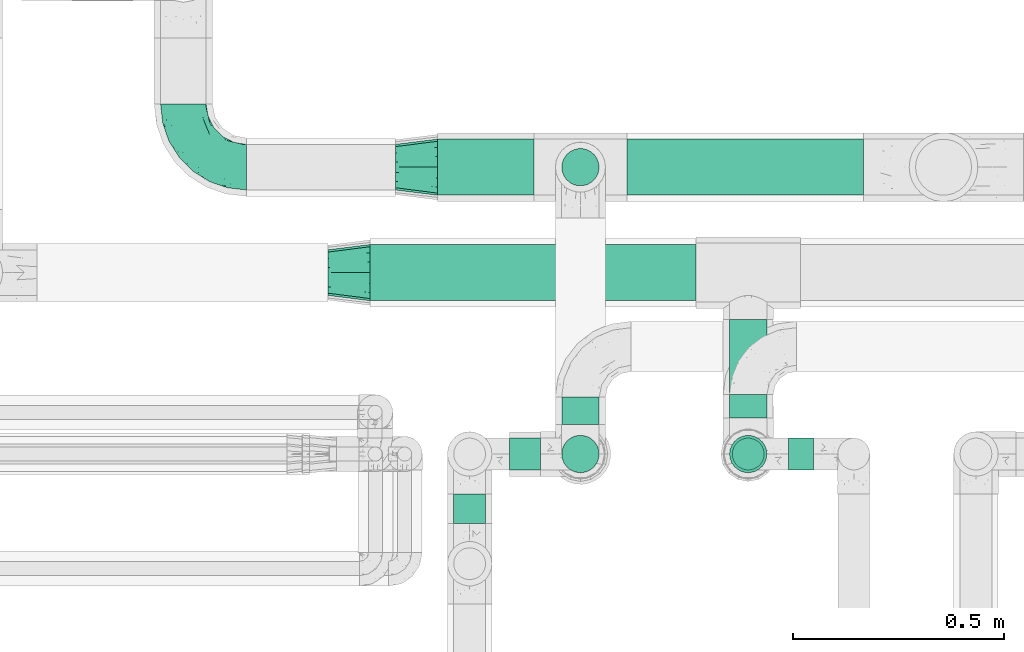
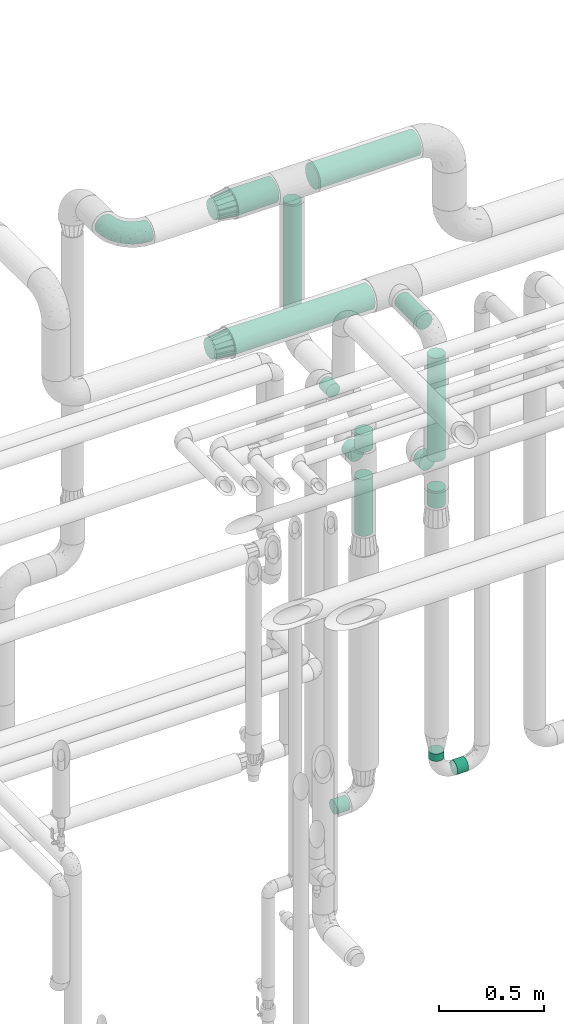
# One storey, part 704 of 827: 15 flow segments, 3 flow fittings.
"""IFC2X3 building model written with IfcOpenShell, lengths in millimetres."""

import ifcopenshell
import ifcopenshell.guid

model = None  # the IFC model being written
_history = None  # IfcOwnerHistory: only IFC2X3 demands one
_inside = {}  # id of a spatial element -> (the spatial element, [elements in it])
_under = {}  # id of a project, library or spatial element -> (it, [spatial elements below it])
_declared = {}  # id of a project -> (the project, [libraries it declares])
_typed = {}  # id of a type object -> (the type object, [elements of that type])
_made_of = {}  # id of a material, layer set ... -> (it, [elements and type objects made of it])


def new_model(schema):
    """Start an empty IFC model of exactly this schema.

    Asked for "IFC4X3", IfcOpenShell would pick the latest addendum, in which some entities
    have other attributes; the version numbers below select the first issue.
    IFC2X3 requires an IfcOwnerHistory on every rooted entity: one is made here for all.
    """
    global model, _history
    if schema == "IFC4X3":
        model = ifcopenshell.file(schema_version=(4, 3, 0, 0))
    else:
        model = ifcopenshell.file(schema=schema)
    _inside.clear()
    _under.clear()
    _declared.clear()
    _typed.clear()
    _made_of.clear()
    _history = None
    if model.schema == "IFC2X3":
        org = make("IfcOrganization", Name="unknown")
        user = make(
            "IfcPersonAndOrganization",
            ThePerson=make("IfcPerson", FamilyName="unknown"),
            TheOrganization=org,
        )
        app = make(
            "IfcApplication",
            ApplicationDeveloper=org,
            Version="unknown",
            ApplicationFullName="unknown",
            ApplicationIdentifier="unknown",
        )
        _history = make(
            "IfcOwnerHistory",
            OwningUser=user,
            OwningApplication=app,
            ChangeAction="ADDED",
            CreationDate=0,
        )
    return model


def make(cls, **values):
    """One entity of the class cls with the attributes given. An attribute that is None is left unset."""
    return model.create_entity(
        cls, **{name: value for name, value in values.items() if value is not None}
    )


def entity(cls, *values):
    """Any entity or typed value of the class cls, its attributes in the order of the schema. None: left unset."""
    e = model.create_entity(cls)
    for i, value in enumerate(values):
        if value is not None:
            e[i] = value
    return e


def rooted(cls, **values):
    """An entity with a GlobalId (a new one), such as an element, a storey or a relation."""
    return make(cls, GlobalId=ifcopenshell.guid.new(), OwnerHistory=_history, **values)


def si_unit(unit_type, name, prefix=None):
    """IfcSIUnit, for example si_unit("LENGTHUNIT", "METRE", prefix="MILLI")."""
    return make("IfcSIUnit", UnitType=unit_type, Prefix=prefix, Name=name)


def converted_unit(unit_type, name, factor, base, dimensions=None, offset=None):
    """IfcConversionBasedUnit, such as the inch: factor (a typed value) times the base unit."""
    return make(
        "IfcConversionBasedUnit"
        if offset is None
        else "IfcConversionBasedUnitWithOffset",
        ConversionOffset=offset,
        Dimensions=None
        if dimensions is None
        else entity("IfcDimensionalExponents", *dimensions),
        UnitType=unit_type,
        Name=name,
        ConversionFactor=make(
            "IfcMeasureWithUnit", ValueComponent=factor, UnitComponent=base
        ),
    )


def derived_unit(unit_type, elements):
    """IfcDerivedUnit: a product of units, each with its exponent."""
    return make(
        "IfcDerivedUnit",
        Elements=[
            make("IfcDerivedUnitElement", Unit=unit, Exponent=power)
            for unit, power in elements
        ],
        UnitType=unit_type,
    )


def assignment(units):
    """IfcUnitAssignment: the units of a project."""
    return None if units is None else make("IfcUnitAssignment", Units=units)


def point(xyz):
    """IfcCartesianPoint."""
    return None if xyz is None else make("IfcCartesianPoint", Coordinates=xyz)


def direction(xyz):
    """IfcDirection."""
    return None if xyz is None else make("IfcDirection", DirectionRatios=xyz)


def frame(location, z_axis=None, x_axis=None):
    """IfcAxis2Placement3D, a coordinate frame: its origin and axes. An axis left out is left unset."""
    return make(
        "IfcAxis2Placement3D",
        Location=point(location),
        Axis=direction(z_axis),
        RefDirection=direction(x_axis),
    )


def frame_2d(location, x_axis=None):
    """IfcAxis2Placement2D, a coordinate frame in the plane: its origin and x axis."""
    return make(
        "IfcAxis2Placement2D", Location=point(location), RefDirection=direction(x_axis)
    )


def origin():
    """The frame at (0, 0, 0) with its axes left unset."""
    return frame((0.0, 0.0, 0.0))


def origin_2d_with_axis():
    """The frame at (0, 0) in the plane with the x axis (1, 0) written out."""
    return frame_2d((0.0, 0.0), x_axis=(1.0, 0.0))


def place(relative_to, where):
    """IfcLocalPlacement: puts the frame where relative to a parent placement (None: the world)."""
    return make(
        "IfcLocalPlacement", PlacementRelTo=relative_to, RelativePlacement=where
    )


def context(
    kind, dimensions, precision=None, world=None, true_north=None, identifier=None
):
    """IfcGeometricRepresentationContext, for example the 3D "Model" context."""
    return make(
        "IfcGeometricRepresentationContext",
        ContextIdentifier=identifier,
        ContextType=kind,
        CoordinateSpaceDimension=dimensions,
        Precision=precision,
        WorldCoordinateSystem=world,
        TrueNorth=true_north,
    )


def subcontext(parent, identifier, kind, view, scale=None):
    """IfcGeometricRepresentationSubContext, for example "Body" below "Model"."""
    return make(
        "IfcGeometricRepresentationSubContext",
        ContextIdentifier=identifier,
        ContextType=kind,
        ParentContext=parent,
        TargetScale=scale,
        TargetView=view,
    )


def project(units=None, contexts=None):
    """IfcProject with its units and contexts."""
    return rooted(
        "IfcProject",
        Name="project",
        RepresentationContexts=contexts,
        UnitsInContext=assignment(units),
    )


def spatial(cls, under=None, at=None, **own):
    """A site, building, storey or space (cls), placed at a placement, below another one or the project."""
    s = rooted(cls, ObjectPlacement=at, **own)
    if under is not None:
        _under.setdefault(under.id(), (under, []))[1].append(s)
    return s


def profile(cls, at=None, kind="AREA", **sizes):
    """A parametric profile (cls). Its sizes go by their IFC names, for example OverallWidth=200.0."""
    return make(cls, ProfileType=kind, Position=at, **sizes)


def circle(**sizes):
    """IfcCircleProfileDef."""
    return profile("IfcCircleProfileDef", **sizes)


def extrude(swept, where, along, depth):
    """IfcExtrudedAreaSolid: the profile swept, set in the frame where, extruded along a direction by depth."""
    return make(
        "IfcExtrudedAreaSolid",
        SweptArea=swept,
        Position=where,
        ExtrudedDirection=direction(along),
        Depth=depth,
    )


def faces_of(points, faces, orient=None, outer=None):
    """IfcFace entities. A face is a list of loops; a loop is a list of indices into points, from 0.

    orient and outer hold one flag for each loop. By default every Orientation is true, the
    first loop of a face is its IfcFaceOuterBound and the others are IfcFaceBound.
    """
    made = []
    for i, loops in enumerate(faces):
        bounds = []
        for j, loop in enumerate(loops):
            is_outer = j == 0 if outer is None else outer[i][j]
            bounds.append(
                make(
                    "IfcFaceOuterBound" if is_outer else "IfcFaceBound",
                    Bound=make("IfcPolyLoop", Polygon=[points[k] for k in loop]),
                    Orientation=True if orient is None else orient[i][j],
                )
            )
        made.append(make("IfcFace", Bounds=bounds))
    return made


def faceted_brep(points, faces, orient=None, outer=None, voids=None):
    """IfcFacetedBrep: a solid bounded by flat faces; with voids (closed shells), ...WithVoids."""
    shared = [point(p) for p in points]
    hull = make("IfcClosedShell", CfsFaces=faces_of(shared, faces, orient, outer))
    if voids is None:
        return make("IfcFacetedBrep", Outer=hull)
    return make(
        "IfcFacetedBrepWithVoids",
        Outer=hull,
        Voids=[
            make(cls, CfsFaces=faces_of(shared, fs, o, b)) for cls, fs, o, b in voids
        ],
    )


def shape(context_of_items, identifier, shape_type, items):
    """IfcShapeRepresentation: the items that make up one representation, for example the "Body"."""
    return make(
        "IfcShapeRepresentation",
        ContextOfItems=context_of_items,
        RepresentationIdentifier=identifier,
        RepresentationType=shape_type,
        Items=items,
    )


def source(mapping_origin, context_of_items, identifier, shape_type, items):
    """IfcRepresentationMap: a shape defined once, which mapped items show again and again."""
    return make(
        "IfcRepresentationMap",
        MappingOrigin=mapping_origin,
        MappedRepresentation=shape(context_of_items, identifier, shape_type, items),
    )


def transform(
    local_origin,
    x_axis=None,
    y_axis=None,
    z_axis=None,
    scale=None,
    scale2=None,
    scale3=None,
    uniform=True,
):
    """IfcCartesianTransformationOperator3D, or its non-uniform kind. x_axis, y_axis, z_axis: its Axis1, 2, 3."""
    if uniform:
        return make(
            "IfcCartesianTransformationOperator3D",
            Axis1=direction(x_axis),
            Axis2=direction(y_axis),
            LocalOrigin=point(local_origin),
            Scale=scale,
            Axis3=direction(z_axis),
        )
    return make(
        "IfcCartesianTransformationOperator3DnonUniform",
        Axis1=direction(x_axis),
        Axis2=direction(y_axis),
        LocalOrigin=point(local_origin),
        Scale=scale,
        Axis3=direction(z_axis),
        Scale2=scale2,
        Scale3=scale3,
    )


def mapped(mapping_source, mapping_target):
    """IfcMappedItem: shows the shape of a source again, moved by a transform."""
    return make(
        "IfcMappedItem", MappingSource=mapping_source, MappingTarget=mapping_target
    )


def material(Name=None, Category=None):
    """IfcMaterial."""
    return make("IfcMaterial", Name=Name, Category=Category)


def made_of(thing, what):
    """Note that an element or type object is made of a material, layer set ...; save() writes the relation."""
    if what is not None:
        _made_of.setdefault(what.id(), (what, []))[1].append(thing)
    return thing


def type_object(cls, material=None, **own):
    """A type object (cls), such as IfcWallType, which elements share."""
    return made_of(rooted(cls, **own), material)


def type_shapes(of_type, sources):
    """Give a type object the sources (RepresentationMaps) that its elements show as mapped items."""
    of_type.RepresentationMaps = sources


def element(
    cls,
    number,
    at=None,
    inside=None,
    cuts=None,
    type_object=None,
    material=None,
    context=None,
    identifier="Body",
    shape_type=None,
    held_by="IfcProductDefinitionShape",
    body=None,
    shapes=None,
    **own,
):
    """One element of the class cls, such as IfcWall. Its Tag is "e" and its number.

    at: its placement. inside: the storey or other place that contains it. cuts: it is an
    opening in that element (IfcRelVoidsElement). A single representation is given by context,
    identifier, shape_type and body (its items); several are given by shapes. held_by: the class
    of the entity that holds the representations. save() writes the other relations.
    """
    e = rooted(cls, Tag="e%d" % number, ObjectPlacement=at, **own)
    if body is not None:
        shapes = [shape(context, identifier, shape_type, body)]
    if shapes is not None:
        e.Representation = make(held_by, Representations=shapes)
    if inside is not None:
        _inside.setdefault(inside.id(), (inside, []))[1].append(e)
    if cuts is not None:
        rooted(
            "IfcRelVoidsElement", RelatingBuildingElement=cuts, RelatedOpeningElement=e
        )
    if type_object is not None:
        _typed.setdefault(type_object.id(), (type_object, []))[1].append(e)
    return made_of(e, material)


def aggregate(whole, parts):
    """IfcRelAggregates: a whole, such as a stair, and the parts it consists of."""
    return rooted("IfcRelAggregates", RelatingObject=whole, RelatedObjects=parts)


def save(model, path):
    """Write the relations noted so far, then the file.

    IfcRelAggregates (storeys below a building ...), IfcRelContainedInSpatialStructure (elements
    in a storey), IfcRelDefinesByType, IfcRelAssociatesMaterial and IfcRelDeclares: one each for
    every whole, place, type object, material and project.
    """
    for whole, parts in _under.values():
        aggregate(whole, parts)
    for where, things in _inside.values():
        rooted(
            "IfcRelContainedInSpatialStructure",
            RelatedElements=things,
            RelatingStructure=where,
        )
    for kind, things in _typed.values():
        rooted("IfcRelDefinesByType", RelatedObjects=things, RelatingType=kind)
    for what, things in _made_of.values():
        rooted("IfcRelAssociatesMaterial", RelatedObjects=things, RelatingMaterial=what)
    for by, libraries in _declared.values():
        rooted("IfcRelDeclares", RelatingContext=by, RelatedDefinitions=libraries)
    model.write(path)


model = new_model("IFC2X3")

# Units and contexts
model_context = context("Model", 3, precision=0.01, world=origin(), true_north=direction((6.12303176911189e-17, 1.0)))
body_context = subcontext(model_context, "Body", "Model", "MODEL_VIEW")
ifc_project = project(units=[si_unit("LENGTHUNIT", "METRE", prefix="MILLI"), si_unit("AREAUNIT", "SQUARE_METRE"), si_unit("VOLUMEUNIT", "CUBIC_METRE"), converted_unit("PLANEANGLEUNIT", "DEGREE", entity("IfcRatioMeasure", 0.0174532925199433), si_unit("PLANEANGLEUNIT", "RADIAN"), dimensions=[0, 0, 0, 0, 0, 0, 0]), si_unit("MASSUNIT", "GRAM", prefix="KILO"), derived_unit("MASSDENSITYUNIT", [(si_unit("MASSUNIT", "GRAM", prefix="KILO"), 1), (si_unit("LENGTHUNIT", "METRE"), -3)]), derived_unit("MOMENTOFINERTIAUNIT", [(si_unit("LENGTHUNIT", "METRE"), 4)]), si_unit("TIMEUNIT", "SECOND"), si_unit("FREQUENCYUNIT", "HERTZ"), si_unit("THERMODYNAMICTEMPERATUREUNIT", "DEGREE_CELSIUS"), derived_unit("THERMALTRANSMITTANCEUNIT", [(si_unit("MASSUNIT", "GRAM", prefix="KILO"), 1), (si_unit("THERMODYNAMICTEMPERATUREUNIT", "KELVIN"), -1), (si_unit("TIMEUNIT", "SECOND"), -3)]), derived_unit("VOLUMETRICFLOWRATEUNIT", [(si_unit("LENGTHUNIT", "METRE"), 3), (si_unit("TIMEUNIT", "SECOND"), -1)]), derived_unit("MASSFLOWRATEUNIT", [(si_unit("MASSUNIT", "GRAM", prefix="KILO"), 1), (si_unit("TIMEUNIT", "SECOND"), -1)]), derived_unit("ROTATIONALFREQUENCYUNIT", [(si_unit("TIMEUNIT", "SECOND"), -1)]), si_unit("ELECTRICCURRENTUNIT", "AMPERE"), si_unit("ELECTRICVOLTAGEUNIT", "VOLT"), si_unit("POWERUNIT", "WATT"), si_unit("FORCEUNIT", "NEWTON", prefix="KILO"), si_unit("ILLUMINANCEUNIT", "LUX"), si_unit("LUMINOUSFLUXUNIT", "LUMEN"), si_unit("LUMINOUSINTENSITYUNIT", "CANDELA"), derived_unit("USERDEFINED", [(si_unit("MASSUNIT", "GRAM", prefix="KILO"), -1), (si_unit("LENGTHUNIT", "METRE"), -2), (si_unit("TIMEUNIT", "SECOND"), 3), (si_unit("LUMINOUSFLUXUNIT", "LUMEN"), 1)]), derived_unit("LINEARVELOCITYUNIT", [(si_unit("LENGTHUNIT", "METRE"), 1), (si_unit("TIMEUNIT", "SECOND"), -1)]), si_unit("PRESSUREUNIT", "PASCAL"), derived_unit("USERDEFINED", [(si_unit("LENGTHUNIT", "METRE"), -2), (si_unit("MASSUNIT", "GRAM", prefix="KILO"), 1), (si_unit("TIMEUNIT", "SECOND"), -2)]), derived_unit("LINEARFORCEUNIT", [(si_unit("MASSUNIT", "GRAM", prefix="KILO"), 1), (si_unit("LENGTHUNIT", "METRE"), 1), (si_unit("TIMEUNIT", "SECOND"), -2), (si_unit("LENGTHUNIT", "METRE"), -1)]), derived_unit("PLANARFORCEUNIT", [(si_unit("MASSUNIT", "GRAM", prefix="KILO"), 1), (si_unit("LENGTHUNIT", "METRE"), 1), (si_unit("TIMEUNIT", "SECOND"), -2), (si_unit("LENGTHUNIT", "METRE"), -2)])], contexts=[model_context])

# Site, building, storey
site_placement = place(None, origin())
site = spatial("IfcSite", under=ifc_project, at=site_placement, CompositionType="ELEMENT")
building_placement = place(site_placement, origin())
building = spatial("IfcBuilding", under=site, at=building_placement, CompositionType="ELEMENT")
storey_placement = place(building_placement, frame((0.0, 0.0, 28200.0)))
storey = spatial("IfcBuildingStorey", under=building, at=storey_placement, Name="08", CompositionType="ELEMENT", Elevation=28200.0)

# Flow segments
pipe_segment_type_1 = type_object("IfcPipeSegmentType", PredefinedType="NOTDEFINED")
flow_segment_1_placement = place(storey_placement, frame((56551.05, 17862.0, 2831.87)))
element("IfcFlowSegment", 1, at=flow_segment_1_placement, inside=storey, type_object=pipe_segment_type_1, context=body_context, shape_type="SweptSolid", body=[
    extrude(circle(Radius=66.5, at=origin_2d_with_axis()), frame((0.0, 68.1, 68.1), z_axis=(1.0, 0.0, 0.0), x_axis=(0.0, 1.0, 0.0)), (0.0, 0.0, 1.0), 772.836562103827),
])
flow_segment_2_placement = place(storey_placement, frame((56711.05, 18112.0, 3431.65)))
element("IfcFlowSegment", 2, at=flow_segment_2_placement, inside=storey, type_object=pipe_segment_type_1, context=body_context, shape_type="SweptSolid", body=[
    extrude(circle(Radius=66.5, at=origin_2d_with_axis()), frame((0.0, 68.1, 68.1), z_axis=(1.0, 0.0, 0.0), x_axis=(0.0, 1.0, 0.0)), (0.0, 0.0, 1.0), 229.02119087204),
])
flow_segment_3_placement = place(storey_placement, frame((57160.07, 18112.0, 3431.65)))
element("IfcFlowSegment", 3, at=flow_segment_3_placement, inside=storey, type_object=pipe_segment_type_1, context=body_context, shape_type="SweptSolid", body=[
    extrude(circle(Radius=66.5, at=origin_2d_with_axis()), frame((0.0, 68.1, 68.1), z_axis=(1.0, 0.0, 0.0), x_axis=(0.0, 1.0, 0.0)), (0.0, 0.0, 1.0), 560.978809127979),
])
pipe_segment_type_2 = type_object("IfcPipeSegmentType", PredefinedType="NOTDEFINED")
flow_segment_4_placement = place(storey_placement, frame((57004.22, 18134.25, 2719.74)))
element("IfcFlowSegment", 4, at=flow_segment_4_placement, inside=storey, type_object=pipe_segment_type_2, context=body_context, shape_type="SweptSolid", body=[
    extrude(circle(Radius=44.25, at=origin_2d_with_axis()), frame((45.85, 45.85, 0.0)), (0.0, 0.0, 1.0), 684.999999999996),
])
flow_segment_5_placement = place(storey_placement, frame((57004.22, 17454.15, 1892.74)))
element("IfcFlowSegment", 5, at=flow_segment_5_placement, inside=storey, type_object=pipe_segment_type_2, context=body_context, shape_type="SweptSolid", body=[
    extrude(circle(Radius=44.25, at=origin_2d_with_axis()), frame((45.85, 45.85, 0.0)), (0.0, 0.0, 1.0), 327.256811194285),
])
flow_segment_6_placement = place(storey_placement, frame((57004.22, 17570.0, 2254.15)))
element("IfcFlowSegment", 6, at=flow_segment_6_placement, inside=storey, type_object=pipe_segment_type_2, context=body_context, shape_type="SweptSolid", body=[
    extrude(circle(Radius=44.25, at=origin_2d_with_axis()), frame((45.85, 0.0, 45.85), z_axis=(0.0, 1.0, 0.0), x_axis=(1.0, 0.0, 0.0)), (0.0, 0.0, 1.0), 65.096114108989),
])
flow_segment_7_placement = place(storey_placement, frame((57004.22, 17454.15, 2380.0)))
element("IfcFlowSegment", 7, at=flow_segment_7_placement, inside=storey, type_object=pipe_segment_type_2, context=body_context, shape_type="SweptSolid", body=[
    extrude(circle(Radius=44.25, at=origin_2d_with_axis()), frame((45.85, 45.85, 0.0)), (0.0, 0.0, 1.0), 99.7431888057308),
])
flow_segment_8_placement = place(storey_placement, frame((56882.39, 17460.65, 313.15)))
element("IfcFlowSegment", 8, at=flow_segment_8_placement, inside=storey, type_object=pipe_segment_type_2, context=body_context, shape_type="SweptSolid", body=[
    extrude(circle(Radius=37.75, at=origin_2d_with_axis()), frame((0.0, 39.35, 39.35), z_axis=(1.0, 0.0, 0.0), x_axis=(0.0, -1.0, 0.0)), (0.0, 0.0, 1.0), 72.6845769329567),
])
flow_segment_9_placement = place(storey_placement, frame((57542.89, 17460.65, 310.65)))
element("IfcFlowSegment", 9, at=flow_segment_9_placement, inside=storey, type_object=pipe_segment_type_2, context=body_context, shape_type="SweptSolid", body=[
    extrude(circle(Radius=37.75, at=origin_2d_with_axis()), frame((0.0, 39.35, 39.35), z_axis=(1.0, 0.0, 0.0), x_axis=(0.0, 1.0, 0.0)), (0.0, 0.0, 1.0), 60.2465000000141),
])
flow_segment_10_placement = place(storey_placement, frame((57408.54, 17460.65, 445.0)))
element("IfcFlowSegment", 10, at=flow_segment_10_placement, inside=storey, type_object=pipe_segment_type_2, context=body_context, shape_type="SweptSolid", body=[
    extrude(circle(Radius=37.75, at=origin_2d_with_axis()), frame((39.35, 39.35, 0.0), z_axis=(0.0, 0.0, 1.0), x_axis=(-1.0, 0.0, 0.0)), (0.0, 0.0, 1.0), 41.9999999999905),
])
flow_segment_11_placement = place(storey_placement, frame((57402.04, 17586.0, 2054.15)))
element("IfcFlowSegment", 11, at=flow_segment_11_placement, inside=storey, type_object=pipe_segment_type_2, context=body_context, shape_type="SweptSolid", body=[
    extrude(circle(Radius=44.25, at=origin_2d_with_axis()), frame((45.85, 0.0, 45.85), z_axis=(0.0, 1.0, 0.0), x_axis=(-1.0, 0.0, 0.0)), (0.0, 0.0, 1.0), 55.0961141089978),
])
flow_segment_12_placement = place(storey_placement, frame((57402.04, 17614.0, 2854.12)))
element("IfcFlowSegment", 12, at=flow_segment_12_placement, inside=storey, type_object=pipe_segment_type_2, context=body_context, shape_type="SweptSolid", body=[
    extrude(circle(Radius=44.25, at=origin_2d_with_axis()), frame((45.85, 0.0, 45.85), z_axis=(0.0, 1.0, 0.0), x_axis=(-1.0, 0.0, 0.0)), (0.0, 0.0, 1.0), 205.096097794299),
])
flow_segment_13_placement = place(storey_placement, frame((57402.04, 17454.15, 1915.45)))
element("IfcFlowSegment", 13, at=flow_segment_13_placement, inside=storey, type_object=pipe_segment_type_2, context=body_context, shape_type="SweptSolid", body=[
    extrude(circle(Radius=44.25, at=origin_2d_with_axis()), frame((45.85, 45.85, 0.0)), (0.0, 0.0, 1.0), 98.5472224728106),
])
flow_segment_14_placement = place(storey_placement, frame((57402.04, 17454.15, 2186.0)))
element("IfcFlowSegment", 14, at=flow_segment_14_placement, inside=storey, type_object=pipe_segment_type_2, context=body_context, shape_type="SweptSolid", body=[
    extrude(circle(Radius=44.25, at=origin_2d_with_axis()), frame((45.85, 45.85, 0.0)), (0.0, 0.0, 1.0), 600.000000000011),
])
flow_segment_15_placement = place(storey_placement, frame((56748.04, 17335.0, 2860.65)))
element("IfcFlowSegment", 15, at=flow_segment_15_placement, inside=storey, type_object=pipe_segment_type_2, context=body_context, shape_type="SweptSolid", body=[
    extrude(circle(Radius=37.75, at=origin_2d_with_axis()), frame((39.35, 0.0, 39.35), z_axis=(0.0, 1.0, 0.0), x_axis=(1.0, 0.0, 0.0)), (0.0, 0.0, 1.0), 70.0000000000187),
])

# Flow fittings
ifc_material = material()
pipe_fitting_type_1 = type_object("IfcPipeFittingType", Name="ADSK_2", PredefinedType="NOTDEFINED", material=ifc_material)
shared_shape_1 = source(origin(), body_context, "Body", "Brep", [
    faceted_brep([(-150.0, 13.98, -52.16), (-150.0, 0.0, -54.0), (-150.0, -13.98, -52.16), (-150.0, -27.0, -46.77), (-150.0, -38.18, -38.18), (-150.0, -46.77, -27.0), (-150.0, -52.16, -13.98), (-150.0, -54.0, 0.0), (-150.0, -52.16, 13.98), (-150.0, -46.77, 27.0), (-150.0, -38.18, 38.18), (-150.0, -27.0, 46.77), (-150.0, -13.98, 52.16), (-150.0, 0.0, 54.0), (-150.0, 13.98, 52.16), (-150.0, 27.0, 46.77), (-150.0, 38.18, 38.18), (-150.0, 46.77, 27.0), (-150.0, 52.16, 13.98), (-150.0, 54.0, 0.0), (-150.0, 52.16, -13.98), (-150.0, 46.77, -27.0), (-150.0, 38.18, -38.18), (-150.0, 27.0, -46.77), (-46.77, 150.0, -27.0), (-52.16, 150.0, -13.98), (-54.0, 150.0, 0.0), (-52.16, 150.0, 13.98), (-46.77, 150.0, 27.0), (-38.18, 150.0, 38.18), (-27.0, 150.0, 46.77), (-13.98, 150.0, 52.16), (0.0, 150.0, 54.0), (13.98, 150.0, 52.16), (27.0, 150.0, 46.77), (38.18, 150.0, 38.18), (46.77, 150.0, 27.0), (52.16, 150.0, 13.98), (54.0, 150.0, 0.0), (52.16, 150.0, -13.98), (46.77, 150.0, -27.0), (38.18, 150.0, -38.18), (27.0, 150.0, -46.77), (13.98, 150.0, -52.16), (0.0, 150.0, -54.0), (-13.98, 150.0, -52.16), (-27.0, 150.0, -46.77), (-38.18, 150.0, -38.18), (-23.02, 116.05, 50.71), (-10.79, 106.96, 53.83), (-99.79, -44.6, 17.82), (-104.61, -48.89, 0.0), (-111.52, -18.45, 48.95), (-64.27, -5.9, 46.22), (-79.66, 4.7, 52.78), (-22.81, -9.49, 0.0), (-44.33, -22.22, 14.35), (-61.49, -33.8, 0.0), (-111.02, -40.26, 31.0), (-106.96, 10.79, 53.83), (-75.79, 19.35, 54.0), (-83.79, 28.63, 52.71), (-6.35, 6.35, 9.57), (22.22, 44.33, 14.35), (-8.95, 8.95, 21.66), (-70.7, -34.05, 19.37), (-77.79, -39.89, 9.53), (-98.78, -28.03, 40.91), (-35.45, -0.96, 36.82), (-24.08, 24.08, 46.13), (-116.99, -5.61, 53.23), (-84.48, 39.18, 49.64), (-116.05, 23.02, 50.71), (28.03, 98.78, 40.91), (-30.84, 79.95, 52.7), (-19.51, 75.72, 54.0), (-52.23, 125.53, 22.23), (-63.5, 102.33, 17.08), (-52.58, 23.63, 53.15), (-23.76, 41.59, 51.45), (-36.39, 47.25, 53.91), (-58.7, 120.33, 0.0), (-125.53, 52.23, 22.23), (-102.33, 63.5, 17.08), (-120.33, 58.7, 0.0), (-59.32, 99.83, 27.68), (-79.36, 79.36, 20.15), (-75.61, 75.61, 30.15), (-114.52, 47.22, 34.83), (-126.22, 33.98, 43.81), (-93.57, 72.33, 0.0), (-47.51, 113.57, 34.88), (18.45, 111.52, 48.95), (5.61, 116.99, 53.23), (48.89, 104.61, 0.0), (44.6, 99.79, 17.82), (37.15, 71.79, 11.16), (5.9, 64.27, 46.22), (-4.7, 79.66, 52.78), (35.09, 74.65, 20.78), (40.26, 111.02, 31.0), (26.44, 65.11, 28.6), (-65.6, -16.94, 39.27), (-65.11, -26.44, 28.6), (-81.51, 81.51, 9.56), (-72.33, 93.57, 0.0), (9.49, 22.81, 0.0), (-35.64, -11.82, 24.43), (-34.23, 124.56, 43.88), (-43.22, 94.57, 45.11), (-69.02, 56.15, 47.3), (-59.26, 74.56, 43.5), (-78.28, 61.88, 39.9), (18.71, 65.93, 37.87), (0.96, 35.45, 36.82), (-59.2, 87.93, 36.27), (33.8, 61.49, 0.0), (-97.33, 42.02, 44.99), (-99.65, 59.35, 27.78), (-56.16, 9.04, 50.42), (11.82, 35.64, 24.43), (-49.6, 72.87, 48.67), (-34.04, 93.29, 49.78), (-57.05, 51.22, 52.06), (-124.56, 34.23, -43.88), (-98.78, -28.03, -40.91), (-79.66, 4.7, -52.78), (-116.99, -5.61, -53.23), (-106.96, 10.79, -53.83), (-99.83, 59.32, -27.68), (-113.57, 47.51, -34.88), (-125.53, 52.23, -22.23), (-116.05, 23.02, -50.71), (-79.95, 30.84, -52.7), (-47.22, 114.52, -34.83), (-102.33, 63.5, -17.08), (40.26, 111.02, -31.0), (-81.51, 81.51, -9.56), (-52.23, 125.53, -22.23), (-94.57, 43.22, -45.11), (-64.27, -5.9, -46.22), (-35.45, -0.96, -36.82), (-65.93, -18.71, -37.87), (-99.79, -44.6, -17.82), (-47.25, 36.39, -53.91), (-75.72, 19.51, -54.0), (-39.18, 84.48, -49.64), (-23.02, 116.05, -50.71), (-28.63, 83.79, -52.71), (-111.02, -40.26, -31.0), (-10.79, 106.96, -53.83), (-19.35, 75.79, -54.0), (-44.33, -22.22, -14.35), (-8.95, 8.95, -21.66), (-6.35, 6.35, -9.57), (-71.79, -37.15, -11.16), (-61.88, 78.28, -39.9), (-74.56, 59.26, -43.5), (-87.93, 59.2, -36.27), (-74.65, -35.09, -20.78), (-65.11, -26.44, -28.6), (0.96, 35.45, -36.82), (-63.5, 102.33, -17.08), (-79.36, 79.36, -20.15), (18.45, 111.52, -48.95), (5.9, 64.27, -46.22), (-4.7, 79.66, -52.78), (-75.61, 75.61, -30.15), (-33.98, 126.22, -43.81), (5.61, 116.99, -53.23), (-23.63, 52.58, -53.15), (-41.59, 23.76, -51.45), (22.22, 44.33, -14.35), (-56.15, 69.02, -47.3), (28.03, 98.78, -40.91), (39.89, 77.79, -9.53), (34.05, 70.7, -19.37), (-111.52, -18.45, -48.95), (44.6, 99.79, -17.82), (26.44, 65.11, -28.6), (11.82, 35.64, -24.43), (16.94, 65.6, -39.27), (-42.02, 97.33, -44.99), (-59.35, 99.65, -27.78), (-24.08, 24.08, -46.13), (-9.04, 56.16, -50.42), (-35.64, -11.82, -24.43), (-72.87, 49.6, -48.67), (-93.29, 34.04, -49.78), (-51.22, 57.05, -52.06)], [[[0, 1, 2, 3, 4, 5, 6, 7, 8, 9, 10, 11, 12, 13, 14, 15, 16, 17, 18, 19, 20, 21, 22, 23]], [[24, 25, 26, 27, 28, 29, 30, 31, 32, 33, 34, 35, 36, 37, 38, 39, 40, 41, 42, 43, 44, 45, 46, 47]], [[31, 48, 49]], [[50, 8, 51]], [[52, 53, 54]], [[8, 50, 9]], [[8, 7, 51]], [[55, 56, 57]], [[58, 9, 50]], [[59, 60, 61]], [[62, 63, 64]], [[65, 66, 56]], [[11, 10, 67]], [[53, 68, 69]], [[67, 52, 11]], [[70, 59, 13]], [[71, 72, 61]], [[73, 35, 34]], [[74, 75, 49]], [[72, 15, 14]], [[13, 59, 14]], [[76, 27, 77]], [[12, 70, 13]], [[78, 79, 80]], [[27, 81, 77]], [[18, 82, 83]], [[72, 14, 59]], [[84, 19, 18]], [[85, 86, 87]], [[88, 16, 89]], [[84, 83, 90]], [[84, 18, 83]], [[15, 89, 16]], [[85, 91, 76]], [[92, 73, 34]], [[49, 32, 31]], [[93, 33, 32]], [[31, 30, 48]], [[94, 95, 96]], [[94, 37, 95]], [[73, 92, 97]], [[98, 93, 49]], [[11, 52, 12]], [[36, 95, 37]], [[99, 100, 101]], [[95, 36, 100]], [[63, 96, 99]], [[100, 36, 35]], [[102, 53, 67]], [[38, 37, 94]], [[92, 34, 33]], [[103, 67, 58]], [[81, 27, 26]], [[104, 105, 90]], [[106, 62, 55]], [[9, 58, 10]], [[91, 29, 28]], [[77, 81, 105]], [[107, 103, 65]], [[49, 48, 74]], [[83, 86, 104]], [[108, 91, 109]], [[16, 88, 17]], [[110, 111, 112]], [[113, 114, 101]], [[108, 30, 29]], [[113, 97, 114]], [[112, 111, 115]], [[66, 51, 57]], [[63, 106, 116]], [[74, 80, 75]], [[82, 18, 17]], [[76, 28, 27]], [[115, 91, 85]], [[112, 88, 117]], [[118, 83, 82]], [[58, 50, 65]], [[67, 10, 58]], [[35, 73, 100]], [[101, 100, 73]], [[53, 52, 67]], [[70, 52, 54]], [[102, 103, 68]], [[119, 78, 54]], [[93, 92, 33]], [[98, 79, 97]], [[98, 97, 92]], [[97, 69, 114]], [[56, 55, 62]], [[56, 107, 65]], [[96, 63, 116]], [[63, 99, 120]], [[108, 48, 30]], [[121, 74, 122]], [[61, 72, 59]], [[89, 72, 117]], [[107, 68, 103]], [[64, 120, 114]], [[69, 68, 114]], [[64, 114, 68]], [[122, 74, 48]], [[74, 123, 80]], [[123, 61, 60]], [[80, 60, 78]], [[49, 93, 32]], [[92, 93, 98]], [[52, 70, 12]], [[59, 70, 54]], [[59, 54, 60]], [[123, 110, 71]], [[78, 60, 54]], [[123, 60, 80]], [[119, 54, 53]], [[78, 119, 79]], [[97, 79, 69]], [[98, 80, 79]], [[53, 69, 119]], [[79, 119, 69]], [[91, 108, 29]], [[108, 109, 122]], [[85, 76, 77]], [[91, 28, 76]], [[86, 85, 77]], [[115, 85, 87]], [[112, 115, 87]], [[109, 91, 115]], [[112, 87, 118]], [[112, 117, 110]], [[71, 110, 117]], [[122, 109, 121]], [[17, 88, 82]], [[118, 87, 86]], [[82, 88, 118]], [[112, 118, 88]], [[80, 98, 75]], [[98, 49, 75]], [[111, 110, 121]], [[115, 111, 109]], [[72, 89, 15]], [[88, 89, 117]], [[72, 71, 117]], [[123, 71, 61]], [[77, 105, 104]], [[118, 86, 83]], [[83, 104, 90]], [[77, 104, 86]], [[63, 62, 106]], [[56, 62, 64]], [[56, 64, 107]], [[68, 107, 64]], [[58, 65, 103]], [[66, 65, 50]], [[51, 66, 50]], [[56, 66, 57]], [[94, 96, 116]], [[99, 96, 95]], [[100, 99, 95]], [[99, 101, 120]], [[114, 120, 101]], [[64, 63, 120]], [[103, 102, 67]], [[68, 53, 102]], [[101, 73, 113]], [[97, 113, 73]], [[108, 122, 48]], [[111, 121, 109]], [[110, 123, 121]], [[74, 121, 123]], [[22, 124, 23]], [[125, 4, 3]], [[126, 127, 128]], [[129, 130, 131]], [[132, 133, 128]], [[128, 1, 0]], [[19, 84, 20]], [[47, 134, 24]], [[90, 135, 84]], [[40, 136, 41]], [[105, 137, 90]], [[131, 20, 135]], [[138, 25, 24]], [[139, 124, 130]], [[130, 22, 21]], [[140, 141, 142]], [[5, 143, 6]], [[133, 144, 145]], [[51, 7, 6]], [[146, 147, 148]], [[143, 5, 149]], [[150, 151, 148]], [[57, 152, 55]], [[153, 154, 152]], [[20, 84, 135]], [[143, 51, 6]], [[143, 155, 51]], [[156, 157, 158]], [[127, 2, 1]], [[159, 149, 160]], [[0, 23, 132]], [[141, 161, 153]], [[162, 163, 137]], [[42, 164, 43]], [[164, 165, 166]], [[44, 150, 45]], [[163, 167, 129]], [[25, 81, 26]], [[0, 132, 128]], [[162, 25, 138]], [[147, 46, 45]], [[47, 168, 134]], [[43, 169, 44]], [[170, 171, 144]], [[81, 25, 162]], [[46, 168, 47]], [[106, 172, 116]], [[150, 147, 45]], [[173, 157, 156]], [[42, 174, 164]], [[55, 154, 106]], [[174, 42, 41]], [[169, 150, 44]], [[175, 172, 176]], [[125, 3, 177]], [[133, 145, 128]], [[178, 40, 39]], [[179, 174, 136]], [[38, 94, 39]], [[152, 155, 159]], [[149, 5, 4]], [[178, 39, 94]], [[175, 94, 116]], [[40, 178, 136]], [[177, 3, 2]], [[179, 176, 180]], [[125, 177, 140]], [[162, 105, 81]], [[181, 165, 174]], [[160, 142, 141]], [[131, 21, 20]], [[158, 130, 129]], [[156, 134, 182]], [[183, 162, 138]], [[4, 125, 149]], [[160, 149, 125]], [[136, 178, 176]], [[174, 41, 136]], [[127, 177, 2]], [[126, 171, 140]], [[126, 140, 177]], [[140, 184, 141]], [[165, 164, 174]], [[169, 164, 166]], [[181, 179, 161]], [[185, 170, 166]], [[155, 152, 57]], [[152, 159, 186]], [[172, 106, 154]], [[172, 180, 176]], [[124, 132, 23]], [[187, 133, 188]], [[148, 147, 150]], [[168, 147, 182]], [[161, 184, 165]], [[186, 141, 153]], [[161, 179, 180]], [[141, 184, 161]], [[188, 133, 132]], [[133, 189, 144]], [[189, 148, 151]], [[144, 151, 170]], [[128, 127, 1]], [[177, 127, 126]], [[164, 169, 43]], [[150, 169, 166]], [[150, 166, 151]], [[189, 173, 146]], [[170, 151, 166]], [[189, 151, 144]], [[185, 166, 165]], [[170, 185, 171]], [[140, 171, 184]], [[126, 144, 171]], [[165, 184, 185]], [[171, 185, 184]], [[130, 124, 22]], [[124, 139, 188]], [[129, 131, 135]], [[130, 21, 131]], [[163, 129, 135]], [[158, 129, 167]], [[156, 158, 167]], [[139, 130, 158]], [[156, 167, 183]], [[156, 182, 173]], [[146, 173, 182]], [[188, 139, 187]], [[24, 134, 138]], [[183, 167, 163]], [[138, 134, 183]], [[156, 183, 134]], [[144, 126, 145]], [[126, 128, 145]], [[157, 173, 187]], [[158, 157, 139]], [[147, 168, 46]], [[134, 168, 182]], [[147, 146, 182]], [[189, 146, 148]], [[135, 90, 137]], [[183, 163, 162]], [[162, 137, 105]], [[135, 137, 163]], [[152, 154, 55]], [[172, 154, 153]], [[51, 155, 57]], [[159, 155, 143]], [[149, 159, 143]], [[159, 160, 186]], [[141, 186, 160]], [[153, 152, 186]], [[172, 153, 180]], [[161, 180, 153]], [[136, 176, 179]], [[175, 176, 178]], [[94, 175, 178]], [[172, 175, 116]], [[160, 125, 142]], [[140, 142, 125]], [[179, 181, 174]], [[161, 165, 181]], [[124, 188, 132]], [[157, 187, 139]], [[173, 189, 187]], [[133, 187, 189]]]),
])
type_shapes(pipe_fitting_type_1, [shared_shape_1])
flow_fitting_placement = place(storey_placement, frame((56108.55, 18180.1, 3499.74), z_axis=(0.0, 0.0, 1.0), x_axis=(0.0, -1.0, 0.0)))
element("IfcFlowFitting", 16, at=flow_fitting_placement, inside=storey, type_object=pipe_fitting_type_1, material=ifc_material, Name="ADSK_2", ObjectType="ADSK_2", context=body_context, shape_type="MappedRepresentation", body=[
    mapped(shared_shape_1, transform((0.0, 0.0, 0.0), scale=1.0)),
])
pipe_fitting_type_2 = type_object("IfcPipeFittingType", Name="ADSK_2", PredefinedType="NOTDEFINED", material=ifc_material)
shared_shape_2 = source(origin(), body_context, "Body", "Brep", [
    faceted_brep([(100.0, 48.65, 23.43), (100.0, 41.16, 32.82), (100.0, 33.67, 42.22), (100.0, 22.84, 47.43), (100.0, 12.02, 52.65), (100.0, 0.0, 52.65), (100.0, -12.02, 52.65), (100.0, -22.84, 47.43), (100.0, -33.67, 42.22), (100.0, -41.16, 32.82), (100.0, -48.65, 23.43), (100.0, -51.33, 11.71), (100.0, -54.0, 0.0), (100.0, -51.33, -11.71), (100.0, -48.65, -23.43), (100.0, -41.16, -32.82), (100.0, -33.67, -42.22), (100.0, -22.84, -47.43), (100.0, -12.02, -52.65), (100.0, 0.0, -52.65), (100.0, 12.02, -52.65), (100.0, 22.84, -47.43), (100.0, 33.67, -42.22), (100.0, 41.16, -32.82), (100.0, 48.65, -23.43), (100.0, 51.33, -11.71), (100.0, 54.0, 0.0), (100.0, 51.33, 11.71), (0.0, 36.24, 54.23), (0.0, 47.02, 47.02), (0.0, 54.23, 36.24), (0.0, 61.44, 25.45), (0.0, 63.97, 12.72), (0.0, 66.5, 0.0), (0.0, 63.97, -12.72), (0.0, 61.44, -25.45), (0.0, 54.23, -36.24), (0.0, 47.02, -47.02), (0.0, 36.24, -54.23), (0.0, 25.45, -61.44), (0.0, 12.72, -63.97), (0.0, 0.0, -66.5), (0.0, -12.72, -63.97), (0.0, -25.45, -61.44), (0.0, -36.24, -54.23), (0.0, -47.02, -47.02), (0.0, -54.23, -36.24), (0.0, -61.44, -25.45), (0.0, -63.97, -12.72), (0.0, -66.5, 0.0), (0.0, -63.97, 12.72), (0.0, -61.44, 25.45), (0.0, -54.23, 36.24), (0.0, -47.02, 47.02), (0.0, -36.24, 54.23), (0.0, -25.45, 61.44), (0.0, -12.72, 63.97), (0.0, 0.0, 66.5), (0.0, 12.72, 63.97), (0.0, 25.45, 61.44)], [[[0, 1, 2, 3, 4, 5, 6, 7, 8, 9, 10, 11, 12, 13, 14, 15, 16, 17, 18, 19, 20, 21, 22, 23, 24, 25, 26, 27]], [[28, 29, 30, 31, 32, 33, 34, 35, 36, 37, 38, 39, 40, 41, 42, 43, 44, 45, 46, 47, 48, 49, 50, 51, 52, 53, 54, 55, 56, 57, 58, 59]], [[24, 35, 25]], [[12, 48, 13]], [[23, 37, 36]], [[40, 39, 20]], [[25, 35, 34]], [[36, 35, 24]], [[38, 21, 39]], [[21, 38, 22]], [[45, 16, 15]], [[40, 20, 19]], [[18, 42, 19]], [[24, 23, 36]], [[18, 43, 42]], [[39, 21, 20]], [[44, 17, 16]], [[38, 37, 22]], [[48, 12, 49]], [[46, 45, 15]], [[48, 47, 13]], [[40, 19, 41]], [[18, 17, 43]], [[26, 34, 33]], [[14, 46, 15]], [[47, 14, 13]], [[26, 25, 34]], [[43, 17, 44]], [[23, 22, 37]], [[46, 14, 47]], [[19, 42, 41]], [[16, 45, 44]], [[10, 51, 11]], [[26, 32, 27]], [[9, 53, 52]], [[56, 55, 6]], [[11, 51, 50]], [[52, 51, 10]], [[54, 7, 55]], [[7, 54, 8]], [[29, 2, 1]], [[56, 6, 5]], [[4, 58, 5]], [[10, 9, 52]], [[4, 59, 58]], [[55, 7, 6]], [[28, 3, 2]], [[54, 53, 8]], [[32, 26, 33]], [[30, 29, 1]], [[32, 31, 27]], [[56, 5, 57]], [[4, 3, 59]], [[12, 50, 49]], [[0, 30, 1]], [[31, 0, 27]], [[12, 11, 50]], [[59, 3, 28]], [[9, 8, 53]], [[30, 0, 31]], [[5, 58, 57]], [[2, 29, 28]]]),
])
type_shapes(pipe_fitting_type_2, [shared_shape_2])
for number, where, z_axis, x_axis, name in (
    (17, (56711.05, 18180.1, 3499.74), (0.0, 0.0, 1.0), (-1.0, 0.0, 0.0), "ADSK_2"),
    (18, (56551.05, 17930.1, 2899.96), (0.0, 0.0, 1.0), (-1.0, 0.0, 0.0), "ADSK_2"),
):
    element("IfcFlowFitting", number, at=place(storey_placement, frame(where, z_axis=z_axis, x_axis=x_axis)), inside=storey, type_object=pipe_fitting_type_2, material=ifc_material, Name=name, ObjectType="ADSK_2", context=body_context, shape_type="MappedRepresentation", body=[
        mapped(shared_shape_2, transform((0.0, 0.0, 0.0), scale=1.0)),
    ])

save(model, "model.ifc")
